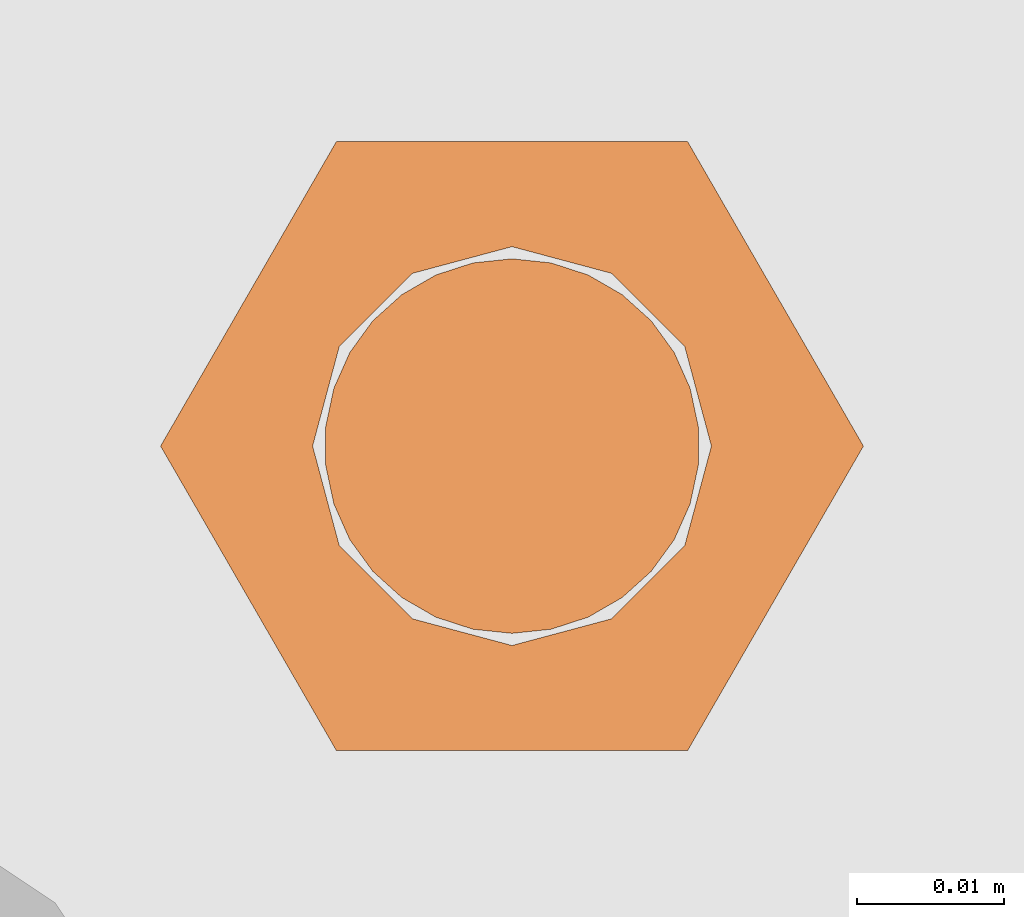
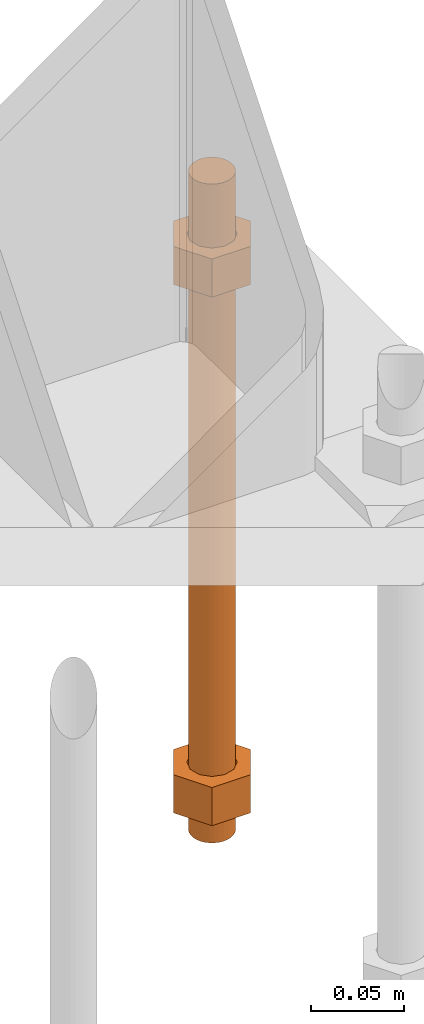
# One storey, part 26 of 89: 1 proxy.
"""IFC4 building model written with IfcOpenShell, lengths in feet."""

import ifcopenshell
import ifcopenshell.guid

model = None  # the IFC model being written
_history = None  # IfcOwnerHistory: only IFC2X3 demands one
_inside = {}  # id of a spatial element -> (the spatial element, [elements in it])
_under = {}  # id of a project, library or spatial element -> (it, [spatial elements below it])
_declared = {}  # id of a project -> (the project, [libraries it declares])
_typed = {}  # id of a type object -> (the type object, [elements of that type])
_made_of = {}  # id of a material, layer set ... -> (it, [elements and type objects made of it])


def new_model(schema):
    """Start an empty IFC model of exactly this schema.

    Asked for "IFC4X3", IfcOpenShell would pick the latest addendum, in which some entities
    have other attributes; the version numbers below select the first issue.
    IFC2X3 requires an IfcOwnerHistory on every rooted entity: one is made here for all.
    """
    global model, _history
    if schema == "IFC4X3":
        model = ifcopenshell.file(schema_version=(4, 3, 0, 0))
    else:
        model = ifcopenshell.file(schema=schema)
    _inside.clear()
    _under.clear()
    _declared.clear()
    _typed.clear()
    _made_of.clear()
    _history = None
    if model.schema == "IFC2X3":
        org = make("IfcOrganization", Name="unknown")
        user = make(
            "IfcPersonAndOrganization",
            ThePerson=make("IfcPerson", FamilyName="unknown"),
            TheOrganization=org,
        )
        app = make(
            "IfcApplication",
            ApplicationDeveloper=org,
            Version="unknown",
            ApplicationFullName="unknown",
            ApplicationIdentifier="unknown",
        )
        _history = make(
            "IfcOwnerHistory",
            OwningUser=user,
            OwningApplication=app,
            ChangeAction="ADDED",
            CreationDate=0,
        )
    return model


def make(cls, **values):
    """One entity of the class cls with the attributes given. An attribute that is None is left unset."""
    return model.create_entity(
        cls, **{name: value for name, value in values.items() if value is not None}
    )


def entity(cls, *values):
    """Any entity or typed value of the class cls, its attributes in the order of the schema. None: left unset."""
    e = model.create_entity(cls)
    for i, value in enumerate(values):
        if value is not None:
            e[i] = value
    return e


def rooted(cls, **values):
    """An entity with a GlobalId (a new one), such as an element, a storey or a relation."""
    return make(cls, GlobalId=ifcopenshell.guid.new(), OwnerHistory=_history, **values)


def si_unit(unit_type, name, prefix=None):
    """IfcSIUnit, for example si_unit("LENGTHUNIT", "METRE", prefix="MILLI")."""
    return make("IfcSIUnit", UnitType=unit_type, Prefix=prefix, Name=name)


def converted_unit(unit_type, name, factor, base, dimensions=None, offset=None):
    """IfcConversionBasedUnit, such as the inch: factor (a typed value) times the base unit."""
    return make(
        "IfcConversionBasedUnit"
        if offset is None
        else "IfcConversionBasedUnitWithOffset",
        ConversionOffset=offset,
        Dimensions=None
        if dimensions is None
        else entity("IfcDimensionalExponents", *dimensions),
        UnitType=unit_type,
        Name=name,
        ConversionFactor=make(
            "IfcMeasureWithUnit", ValueComponent=factor, UnitComponent=base
        ),
    )


def derived_unit(unit_type, elements):
    """IfcDerivedUnit: a product of units, each with its exponent."""
    return make(
        "IfcDerivedUnit",
        Elements=[
            make("IfcDerivedUnitElement", Unit=unit, Exponent=power)
            for unit, power in elements
        ],
        UnitType=unit_type,
    )


def assignment(units):
    """IfcUnitAssignment: the units of a project."""
    return None if units is None else make("IfcUnitAssignment", Units=units)


def point(xyz):
    """IfcCartesianPoint."""
    return None if xyz is None else make("IfcCartesianPoint", Coordinates=xyz)


def direction(xyz):
    """IfcDirection."""
    return None if xyz is None else make("IfcDirection", DirectionRatios=xyz)


def frame(location, z_axis=None, x_axis=None):
    """IfcAxis2Placement3D, a coordinate frame: its origin and axes. An axis left out is left unset."""
    return make(
        "IfcAxis2Placement3D",
        Location=point(location),
        Axis=direction(z_axis),
        RefDirection=direction(x_axis),
    )


def origin():
    """The frame at (0, 0, 0) with its axes left unset."""
    return frame((0.0, 0.0, 0.0))


def place(relative_to, where):
    """IfcLocalPlacement: puts the frame where relative to a parent placement (None: the world)."""
    return make(
        "IfcLocalPlacement", PlacementRelTo=relative_to, RelativePlacement=where
    )


def context(
    kind, dimensions, precision=None, world=None, true_north=None, identifier=None
):
    """IfcGeometricRepresentationContext, for example the 3D "Model" context."""
    return make(
        "IfcGeometricRepresentationContext",
        ContextIdentifier=identifier,
        ContextType=kind,
        CoordinateSpaceDimension=dimensions,
        Precision=precision,
        WorldCoordinateSystem=world,
        TrueNorth=true_north,
    )


def subcontext(parent, identifier, kind, view, scale=None):
    """IfcGeometricRepresentationSubContext, for example "Body" below "Model"."""
    return make(
        "IfcGeometricRepresentationSubContext",
        ContextIdentifier=identifier,
        ContextType=kind,
        ParentContext=parent,
        TargetScale=scale,
        TargetView=view,
    )


def project(units=None, contexts=None):
    """IfcProject with its units and contexts."""
    return rooted(
        "IfcProject",
        Name="project",
        RepresentationContexts=contexts,
        UnitsInContext=assignment(units),
    )


def spatial(cls, under=None, at=None, **own):
    """A site, building, storey or space (cls), placed at a placement, below another one or the project."""
    s = rooted(cls, ObjectPlacement=at, **own)
    if under is not None:
        _under.setdefault(under.id(), (under, []))[1].append(s)
    return s


def faces_of(points, faces, orient=None, outer=None):
    """IfcFace entities. A face is a list of loops; a loop is a list of indices into points, from 0.

    orient and outer hold one flag for each loop. By default every Orientation is true, the
    first loop of a face is its IfcFaceOuterBound and the others are IfcFaceBound.
    """
    made = []
    for i, loops in enumerate(faces):
        bounds = []
        for j, loop in enumerate(loops):
            is_outer = j == 0 if outer is None else outer[i][j]
            bounds.append(
                make(
                    "IfcFaceOuterBound" if is_outer else "IfcFaceBound",
                    Bound=make("IfcPolyLoop", Polygon=[points[k] for k in loop]),
                    Orientation=True if orient is None else orient[i][j],
                )
            )
        made.append(make("IfcFace", Bounds=bounds))
    return made


def faceted_brep(points, faces, orient=None, outer=None, voids=None):
    """IfcFacetedBrep: a solid bounded by flat faces; with voids (closed shells), ...WithVoids."""
    shared = [point(p) for p in points]
    hull = make("IfcClosedShell", CfsFaces=faces_of(shared, faces, orient, outer))
    if voids is None:
        return make("IfcFacetedBrep", Outer=hull)
    return make(
        "IfcFacetedBrepWithVoids",
        Outer=hull,
        Voids=[
            make(cls, CfsFaces=faces_of(shared, fs, o, b)) for cls, fs, o, b in voids
        ],
    )


def shape(context_of_items, identifier, shape_type, items):
    """IfcShapeRepresentation: the items that make up one representation, for example the "Body"."""
    return make(
        "IfcShapeRepresentation",
        ContextOfItems=context_of_items,
        RepresentationIdentifier=identifier,
        RepresentationType=shape_type,
        Items=items,
    )


def source(mapping_origin, context_of_items, identifier, shape_type, items):
    """IfcRepresentationMap: a shape defined once, which mapped items show again and again."""
    return make(
        "IfcRepresentationMap",
        MappingOrigin=mapping_origin,
        MappedRepresentation=shape(context_of_items, identifier, shape_type, items),
    )


def transform(
    local_origin,
    x_axis=None,
    y_axis=None,
    z_axis=None,
    scale=None,
    scale2=None,
    scale3=None,
    uniform=True,
):
    """IfcCartesianTransformationOperator3D, or its non-uniform kind. x_axis, y_axis, z_axis: its Axis1, 2, 3."""
    if uniform:
        return make(
            "IfcCartesianTransformationOperator3D",
            Axis1=direction(x_axis),
            Axis2=direction(y_axis),
            LocalOrigin=point(local_origin),
            Scale=scale,
            Axis3=direction(z_axis),
        )
    return make(
        "IfcCartesianTransformationOperator3DnonUniform",
        Axis1=direction(x_axis),
        Axis2=direction(y_axis),
        LocalOrigin=point(local_origin),
        Scale=scale,
        Axis3=direction(z_axis),
        Scale2=scale2,
        Scale3=scale3,
    )


def mapped(mapping_source, mapping_target):
    """IfcMappedItem: shows the shape of a source again, moved by a transform."""
    return make(
        "IfcMappedItem", MappingSource=mapping_source, MappingTarget=mapping_target
    )


def material(Name=None, Category=None):
    """IfcMaterial."""
    return make("IfcMaterial", Name=Name, Category=Category)


def constituent(of_material, Name=None, Category=None, fraction=None):
    """IfcMaterialConstituent: one of the materials an element consists of."""
    return make(
        "IfcMaterialConstituent",
        Name=Name,
        Material=of_material,
        Fraction=fraction,
        Category=Category,
    )


def constituent_set(constituents=None, Name=None):
    """IfcMaterialConstituentSet."""
    return make(
        "IfcMaterialConstituentSet", Name=Name, MaterialConstituents=constituents
    )


def made_of(thing, what):
    """Note that an element or type object is made of a material, layer set ...; save() writes the relation."""
    if what is not None:
        _made_of.setdefault(what.id(), (what, []))[1].append(thing)
    return thing


def type_object(cls, material=None, **own):
    """A type object (cls), such as IfcWallType, which elements share."""
    return made_of(rooted(cls, **own), material)


def type_shapes(of_type, sources):
    """Give a type object the sources (RepresentationMaps) that its elements show as mapped items."""
    of_type.RepresentationMaps = sources


def element(
    cls,
    number,
    at=None,
    inside=None,
    cuts=None,
    type_object=None,
    material=None,
    context=None,
    identifier="Body",
    shape_type=None,
    held_by="IfcProductDefinitionShape",
    body=None,
    shapes=None,
    **own,
):
    """One element of the class cls, such as IfcWall. Its Tag is "e" and its number.

    at: its placement. inside: the storey or other place that contains it. cuts: it is an
    opening in that element (IfcRelVoidsElement). A single representation is given by context,
    identifier, shape_type and body (its items); several are given by shapes. held_by: the class
    of the entity that holds the representations. save() writes the other relations.
    """
    e = rooted(cls, Tag="e%d" % number, ObjectPlacement=at, **own)
    if body is not None:
        shapes = [shape(context, identifier, shape_type, body)]
    if shapes is not None:
        e.Representation = make(held_by, Representations=shapes)
    if inside is not None:
        _inside.setdefault(inside.id(), (inside, []))[1].append(e)
    if cuts is not None:
        rooted(
            "IfcRelVoidsElement", RelatingBuildingElement=cuts, RelatedOpeningElement=e
        )
    if type_object is not None:
        _typed.setdefault(type_object.id(), (type_object, []))[1].append(e)
    return made_of(e, material)


def aggregate(whole, parts):
    """IfcRelAggregates: a whole, such as a stair, and the parts it consists of."""
    return rooted("IfcRelAggregates", RelatingObject=whole, RelatedObjects=parts)


def save(model, path):
    """Write the relations noted so far, then the file.

    IfcRelAggregates (storeys below a building ...), IfcRelContainedInSpatialStructure (elements
    in a storey), IfcRelDefinesByType, IfcRelAssociatesMaterial and IfcRelDeclares: one each for
    every whole, place, type object, material and project.
    """
    for whole, parts in _under.values():
        aggregate(whole, parts)
    for where, things in _inside.values():
        rooted(
            "IfcRelContainedInSpatialStructure",
            RelatedElements=things,
            RelatingStructure=where,
        )
    for kind, things in _typed.values():
        rooted("IfcRelDefinesByType", RelatedObjects=things, RelatingType=kind)
    for what, things in _made_of.values():
        rooted("IfcRelAssociatesMaterial", RelatedObjects=things, RelatingMaterial=what)
    for by, libraries in _declared.values():
        rooted("IfcRelDeclares", RelatingContext=by, RelatedDefinitions=libraries)
    model.write(path)


model = new_model("IFC4")

# Units and contexts
model_context = context("Model", 3, precision=0.0001, world=origin(), true_north=direction((6.12303176911189e-17, 1.0)))
body_context = subcontext(model_context, "Body", "Model", "MODEL_VIEW")
ifc_project = project(units=[converted_unit("LENGTHUNIT", "FOOT", entity("IfcRatioMeasure", 0.3048), si_unit("LENGTHUNIT", "METRE"), dimensions=[1, 0, 0, 0, 0, 0, 0]), converted_unit("AREAUNIT", "SQUARE FOOT", entity("IfcRatioMeasure", 0.09290304), si_unit("AREAUNIT", "SQUARE_METRE"), dimensions=[2, 0, 0, 0, 0, 0, 0]), converted_unit("VOLUMEUNIT", "CUBIC FOOT", entity("IfcRatioMeasure", 0.028316846592), si_unit("VOLUMEUNIT", "CUBIC_METRE"), dimensions=[3, 0, 0, 0, 0, 0, 0]), si_unit("PLANEANGLEUNIT", "RADIAN"), si_unit("MASSUNIT", "GRAM", prefix="KILO"), derived_unit("MASSDENSITYUNIT", [(si_unit("MASSUNIT", "GRAM", prefix="KILO"), 1), (si_unit("LENGTHUNIT", "METRE"), -3)]), derived_unit("MOMENTOFINERTIAUNIT", [(si_unit("LENGTHUNIT", "METRE"), 4)]), si_unit("TIMEUNIT", "SECOND"), si_unit("FREQUENCYUNIT", "HERTZ"), si_unit("THERMODYNAMICTEMPERATUREUNIT", "DEGREE_CELSIUS"), derived_unit("THERMALTRANSMITTANCEUNIT", [(si_unit("MASSUNIT", "GRAM", prefix="KILO"), 1), (si_unit("THERMODYNAMICTEMPERATUREUNIT", "KELVIN"), -1), (si_unit("TIMEUNIT", "SECOND"), -3)]), derived_unit("VOLUMETRICFLOWRATEUNIT", [(si_unit("LENGTHUNIT", "METRE"), 3), (si_unit("TIMEUNIT", "SECOND"), -1)]), si_unit("ELECTRICCURRENTUNIT", "AMPERE"), si_unit("ELECTRICVOLTAGEUNIT", "VOLT"), si_unit("POWERUNIT", "WATT"), si_unit("FORCEUNIT", "NEWTON"), si_unit("ILLUMINANCEUNIT", "LUX"), si_unit("LUMINOUSFLUXUNIT", "LUMEN"), si_unit("LUMINOUSINTENSITYUNIT", "CANDELA"), derived_unit("USERDEFINED", [(si_unit("MASSUNIT", "GRAM", prefix="KILO"), -1), (si_unit("LENGTHUNIT", "METRE"), -2), (si_unit("TIMEUNIT", "SECOND"), 3), (si_unit("LUMINOUSFLUXUNIT", "LUMEN"), 1)]), derived_unit("LINEARVELOCITYUNIT", [(si_unit("LENGTHUNIT", "METRE"), 1), (si_unit("TIMEUNIT", "SECOND"), -1)]), si_unit("PRESSUREUNIT", "PASCAL"), derived_unit("USERDEFINED", [(si_unit("LENGTHUNIT", "METRE"), -2), (si_unit("MASSUNIT", "GRAM", prefix="KILO"), 1), (si_unit("TIMEUNIT", "SECOND"), -2)]), derived_unit("LINEARFORCEUNIT", [(si_unit("MASSUNIT", "GRAM", prefix="KILO"), 1), (si_unit("LENGTHUNIT", "METRE"), 1), (si_unit("TIMEUNIT", "SECOND"), -2), (si_unit("LENGTHUNIT", "METRE"), -1)]), derived_unit("PLANARFORCEUNIT", [(si_unit("MASSUNIT", "GRAM", prefix="KILO"), 1), (si_unit("LENGTHUNIT", "METRE"), 1), (si_unit("TIMEUNIT", "SECOND"), -2), (si_unit("LENGTHUNIT", "METRE"), -2)])], contexts=[model_context])

# Site, building, storey
site_placement = place(None, origin())
site = spatial("IfcSite", under=ifc_project, at=site_placement, CompositionType="ELEMENT")
building_placement = place(site_placement, frame((-472.238160486, -49.138065117, 0.0)))
building = spatial("IfcBuilding", under=site, at=building_placement, CompositionType="ELEMENT")
storey_placement = place(building_placement, origin())
storey = spatial("IfcBuildingStorey", under=building, at=storey_placement, Name="Level 1", CompositionType="ELEMENT", Elevation=0.0)

# Proxy
ifc_material_1 = material(Name="Color 7721", Category="Materials")
ifc_constituent_1 = constituent(ifc_material_1, Name="Color 7721", Category="Materials")
ifc_material_2 = material(Name="Color 7720", Category="Materials")
ifc_constituent_2 = constituent(ifc_material_2, Name="Color 7720", Category="Materials")
ifc_constituent_set = constituent_set(constituents=[ifc_constituent_1, ifc_constituent_2])
building_element_proxy_type = type_object("IfcBuildingElementProxyType", Name="rb2", PredefinedType="NOTDEFINED", material=ifc_material_1)
shared_shape = source(origin(), body_context, "Body", "Brep", [
    faceted_brep([(0.122545547339286, 0.0677083333333712, 0.0626666666666664), (0.156365697905557, 0.0677083333333712, 0.0626666666666664), (0.11727427342916, 0.135416666666742, 0.0626666666666664), (0.0390914244764247, 0.135416666666742, 0.0626666666666664), (0.0, 0.0677083333333712, 0.0626666666666664), (0.0338201505662994, 0.0677083333333712, 0.0626666666666664), (0.0397636251696838, 0.089889682526632, 0.0626666666666664), (0.0560014997595601, 0.106127557116452, 0.0626666666666664), (0.0781828489527925, 0.112071031719893, 0.0626666666666664), (0.100364198146025, 0.106127557116452, 0.0626666666666664), (0.116602072735901, 0.089889682526632, 0.0626666666666664), (0.11727427342916, 0.0, 0.0626666666666664), (0.0390914244764247, 0.0, 0.0626666666666664), (0.0397636251696838, 0.0455269841401105, 0.0626666666666664), (0.0560014997595601, 0.029289109550291, 0.0626666666666664), (0.0781828489527925, 0.0233456349468497, 0.0626666666666664), (0.100364198146025, 0.029289109550291, 0.0626666666666664), (0.116602072735901, 0.0455269841401105, 0.0626666666666664), (0.0, 0.0677083333333712, 0.144697916666667), (0.0390914244763962, 0.135416666666742, 0.144697916666667), (0.11727427342916, 0.135416666666742, 0.144697916666667), (0.156365697905528, 0.0677083333333712, 0.144697916666667), (0.117274273429189, 0.0, 0.144697916666667), (0.0390914244764247, 0.0, 0.144697916666667), (0.122545547339286, 0.0677083333333712, 0.144697916666666), (0.0338201505662994, 0.0677083333333712, 0.144697916666666), (0.0397636251696838, 0.0455269841401105, 0.144697916666666), (0.0560014997595601, 0.029289109550291, 0.144697916666666), (0.0781828489527925, 0.0233456349468497, 0.144697916666666), (0.100364198146025, 0.029289109550291, 0.144697916666666), (0.116602072735901, 0.0455269841401105, 0.144697916666666), (0.0397636251696838, 0.089889682526632, 0.144697916666666), (0.0560014997595601, 0.106127557116452, 0.144697916666666), (0.0781828489527925, 0.112071031719893, 0.144697916666666), (0.100364198146025, 0.106127557116452, 0.144697916666666), (0.116602072735901, 0.089889682526632, 0.144697916666666)], [[[0, 1, 2, 3, 4, 5, 6, 7, 8, 9, 10]], [[1, 11, 12, 4, 5, 13, 14, 15, 16, 17, 0]], [[4, 18, 19, 3]], [[3, 19, 20, 2]], [[2, 20, 21, 1]], [[1, 21, 22, 11]], [[11, 22, 23, 12]], [[12, 23, 18, 4]], [[24, 21, 22, 23, 18, 25, 26, 27, 28, 29, 30]], [[21, 20, 19, 18, 25, 31, 32, 33, 34, 35, 24]], [[25, 5, 6, 31]], [[31, 6, 7, 32]], [[32, 7, 8, 33]], [[33, 8, 9, 34]], [[34, 9, 10, 35]], [[35, 10, 0, 24]], [[24, 0, 17, 30]], [[30, 17, 16, 29]], [[29, 16, 15, 28]], [[28, 15, 14, 27]], [[27, 14, 13, 26]], [[26, 13, 5, 25]]]),
    faceted_brep([(0.0338201505662994, 0.0677083333333712, 1.28108333333333), (0.0, 0.0677083333333712, 1.28108333333333), (0.0390914244764247, 0.135416666666742, 1.28108333333333), (0.11727427342916, 0.135416666666742, 1.28108333333333), (0.156365697905557, 0.0677083333333712, 1.28108333333333), (0.122545547339286, 0.0677083333333712, 1.28108333333333), (0.116602072735901, 0.089889682526632, 1.28108333333333), (0.100364198146025, 0.106127557116452, 1.28108333333333), (0.0781828489527925, 0.112071031719893, 1.28108333333333), (0.0560014997595601, 0.106127557116452, 1.28108333333333), (0.0397636251696838, 0.089889682526632, 1.28108333333333), (0.0390914244764247, 0.0, 1.28108333333333), (0.11727427342916, 0.0, 1.28108333333333), (0.116602072735901, 0.0455269841401105, 1.28108333333333), (0.100364198146025, 0.029289109550291, 1.28108333333333), (0.0781828489527925, 0.0233456349468497, 1.28108333333333), (0.0560014997595601, 0.029289109550291, 1.28108333333333), (0.0397636251696838, 0.0455269841401105, 1.28108333333333), (0.156365697905585, 0.0677083333333712, 1.19905208333333), (0.117274273429189, 0.135416666666742, 1.19905208333333), (0.0390914244764247, 0.135416666666742, 1.19905208333333), (0.0, 0.0677083333333712, 1.19905208333333), (0.0390914244763962, 0.0, 1.19905208333333), (0.11727427342916, 0.0, 1.19905208333333), (0.0338201505662994, 0.0677083333333712, 1.19905208333333), (0.122545547339286, 0.0677083333333712, 1.19905208333333), (0.116602072735901, 0.0455269841401105, 1.19905208333333), (0.100364198146025, 0.029289109550291, 1.19905208333333), (0.0781828489527925, 0.0233456349468497, 1.19905208333333), (0.0560014997595601, 0.029289109550291, 1.19905208333333), (0.0397636251696838, 0.0455269841401105, 1.19905208333333), (0.116602072735901, 0.089889682526632, 1.19905208333333), (0.100364198146025, 0.106127557116452, 1.19905208333333), (0.0781828489527925, 0.112071031719893, 1.19905208333333), (0.0560014997595601, 0.106127557116452, 1.19905208333333), (0.0397636251696838, 0.089889682526632, 1.19905208333333)], [[[0, 1, 2, 3, 4, 5, 6, 7, 8, 9, 10]], [[1, 11, 12, 4, 5, 13, 14, 15, 16, 17, 0]], [[4, 18, 19, 3]], [[3, 19, 20, 2]], [[2, 20, 21, 1]], [[1, 21, 22, 11]], [[11, 22, 23, 12]], [[12, 23, 18, 4]], [[24, 21, 22, 23, 18, 25, 26, 27, 28, 29, 30]], [[21, 20, 19, 18, 25, 31, 32, 33, 34, 35, 24]], [[25, 5, 6, 31]], [[31, 6, 7, 32]], [[32, 7, 8, 33]], [[33, 8, 9, 34]], [[34, 9, 10, 35]], [[35, 10, 0, 24]], [[24, 0, 17, 30]], [[30, 17, 16, 29]], [[29, 16, 15, 28]], [[28, 15, 14, 27]], [[27, 14, 13, 26]], [[26, 13, 5, 25]]]),
    faceted_brep([(0.0781828489527925, 0.0260416666667425, 0.0), (0.0695198618353743, 0.0269521833027966, 0.0), (0.0612354888246216, 0.029643939264929, 0.0), (0.0536917967739328, 0.0339992919010683, 0.0), (0.0472184812245757, 0.0398278914017283, 0.0), (0.0420984571284464, 0.046875, 0.0), (0.0385554941071575, 0.0548326252344395, 0.0), (0.0367444366457903, 0.0633529806972319, 0.0), (0.0367444366457903, 0.0720636859695105, 0.0), (0.0385554941071575, 0.0805840414323029, 0.0), (0.0420984571284464, 0.0885416666667425, 0.0), (0.0472184812245757, 0.0955887752650142, 0.0), (0.0536917967739328, 0.101417374765674, 0.0), (0.0612354888246216, 0.105772727401813, 0.0), (0.0695198618353743, 0.108464483363946, 0.0), (0.0781828489527925, 0.109375, 0.0), (0.0868458360702107, 0.108464483363946, 0.0), (0.0951302090809634, 0.105772727401813, 0.0), (0.102673901131652, 0.101417374765674, 0.0), (0.109147216681009, 0.0955887752650142, 0.0), (0.114267240777139, 0.0885416666667425, 0.0), (0.117810203798427, 0.0805840414323029, 0.0), (0.119621261259795, 0.0720636859695105, 0.0), (0.119621261259795, 0.0633529806972319, 0.0), (0.117810203798427, 0.0548326252344395, 0.0), (0.114267240777139, 0.046875, 0.0), (0.109147216681009, 0.0398278914017283, 0.0), (0.102673901131652, 0.0339992919010683, 0.0), (0.0951302090809634, 0.029643939264929, 0.0), (0.0868458360702107, 0.0269521833027966, 0.0), (0.0868458360702107, 0.0269521833027966, 1.41666666666667), (0.0951302090809634, 0.029643939264929, 1.41666666666667), (0.102673901131652, 0.0339992919010683, 1.41666666666667), (0.109147216681009, 0.0398278914017283, 1.41666666666667), (0.114267240777139, 0.046875, 1.41666666666667), (0.117810203798427, 0.0548326252344395, 1.41666666666667), (0.119621261259795, 0.0633529806972319, 1.41666666666667), (0.119621261259795, 0.0720636859695105, 1.41666666666667), (0.117810203798427, 0.0805840414323029, 1.41666666666667), (0.114267240777139, 0.0885416666667425, 1.41666666666667), (0.109147216681009, 0.0955887752650142, 1.41666666666667), (0.102673901131652, 0.101417374765674, 1.41666666666667), (0.0951302090809634, 0.105772727401813, 1.41666666666667), (0.0868458360702107, 0.108464483363946, 1.41666666666667), (0.0781828489527925, 0.109375, 1.41666666666667), (0.0695198618353743, 0.108464483363946, 1.41666666666667), (0.0612354888246216, 0.105772727401813, 1.41666666666667), (0.0536917967739328, 0.101417374765674, 1.41666666666667), (0.0472184812245757, 0.0955887752650142, 1.41666666666667), (0.0420984571284464, 0.0885416666667425, 1.41666666666667), (0.0385554941071575, 0.0805840414323029, 1.41666666666667), (0.0367444366457903, 0.0720636859695105, 1.41666666666667), (0.0367444366457903, 0.0633529806972319, 1.41666666666667), (0.0385554941071575, 0.0548326252344395, 1.41666666666667), (0.0420984571284464, 0.046875, 1.41666666666667), (0.0472184812245757, 0.0398278914017283, 1.41666666666667), (0.0536917967739328, 0.0339992919010683, 1.41666666666667), (0.0612354888246216, 0.029643939264929, 1.41666666666667), (0.0695198618353743, 0.0269521833027966, 1.41666666666667), (0.0781828489527925, 0.0260416666667425, 1.41666666666667), (0.0695198618353743, 0.0269521833027966, 0.25), (0.0781828489527925, 0.0260416666667425, 0.25), (0.0612354888246216, 0.029643939264929, 0.25), (0.0536917967739328, 0.0339992919010683, 0.25), (0.0472184812246326, 0.0398278914017283, 0.25), (0.0420984571284464, 0.046875, 0.25), (0.0385554941071575, 0.0548326252344395, 0.25), (0.0367444366457903, 0.0633529806972319, 0.25), (0.0367444366457903, 0.0720636859695105, 0.25), (0.038555494107186, 0.0805840414323029, 0.25), (0.0420984571284464, 0.0885416666667425, 0.25), (0.0472184812245757, 0.0955887752650142, 0.25), (0.0536917967738759, 0.101417374765674, 0.25), (0.0612354888246216, 0.105772727401813, 0.25), (0.0695198618353743, 0.108464483363946, 0.25), (0.0781828489527925, 0.109375, 0.25), (0.0868458360702107, 0.108464483363946, 0.25), (0.0951302090809634, 0.105772727401813, 0.25), (0.102673901131652, 0.101417374765674, 0.25), (0.109147216680952, 0.0955887752650142, 0.25), (0.114267240777139, 0.0885416666667425, 0.25), (0.117810203798427, 0.0805840414323029, 0.25), (0.119621261259795, 0.0720636859695105, 0.25), (0.119621261259795, 0.0633529806972319, 0.25), (0.117810203798399, 0.0548326252344395, 0.25), (0.114267240777139, 0.046875, 0.25), (0.109147216681009, 0.0398278914017283, 0.25), (0.102673901131709, 0.0339992919010683, 0.25), (0.0951302090809634, 0.029643939264929, 0.25), (0.0868458360702107, 0.0269521833027966, 0.25), (0.0695198618353743, 0.0269521833027966, 0.916666666666667), (0.0781828489527925, 0.0260416666667425, 0.916666666666667), (0.0612354888246216, 0.029643939264929, 0.916666666666667), (0.0536917967739328, 0.0339992919010683, 0.916666666666667), (0.0472184812246326, 0.0398278914017283, 0.916666666666667), (0.0420984571284464, 0.046875, 0.916666666666667), (0.0385554941071575, 0.0548326252344395, 0.916666666666667), (0.0367444366457903, 0.0633529806972319, 0.916666666666667), (0.0367444366457903, 0.0720636859695105, 0.916666666666667), (0.038555494107186, 0.0805840414323029, 0.916666666666667), (0.0420984571284464, 0.0885416666667425, 0.916666666666667), (0.0472184812245757, 0.0955887752650142, 0.916666666666667), (0.0536917967738759, 0.101417374765674, 0.916666666666667), (0.0612354888246216, 0.105772727401813, 0.916666666666667), (0.0695198618353743, 0.108464483363946, 0.916666666666667), (0.0781828489527925, 0.109375, 0.916666666666667), (0.0868458360702107, 0.108464483363946, 0.916666666666667), (0.0951302090809634, 0.105772727401813, 0.916666666666667), (0.102673901131652, 0.101417374765674, 0.916666666666667), (0.109147216680952, 0.0955887752650142, 0.916666666666667), (0.114267240777139, 0.0885416666667425, 0.916666666666667), (0.117810203798427, 0.0805840414323029, 0.916666666666667), (0.119621261259795, 0.0720636859695105, 0.916666666666667), (0.119621261259795, 0.0633529806972319, 0.916666666666667), (0.117810203798399, 0.0548326252344395, 0.916666666666667), (0.114267240777139, 0.046875, 0.916666666666667), (0.109147216681009, 0.0398278914017283, 0.916666666666667), (0.102673901131709, 0.0339992919010683, 0.916666666666667), (0.0951302090809634, 0.029643939264929, 0.916666666666667), (0.0868458360702107, 0.0269521833027966, 0.916666666666667)], [[[0, 1, 2, 3, 4, 5, 6, 7, 8, 9, 10, 11, 12, 13, 14, 15, 16, 17, 18, 19, 20, 21, 22, 23, 24, 25, 26, 27, 28, 29]], [[30, 31, 32, 33, 34, 35, 36, 37, 38, 39, 40, 41, 42, 43, 44, 45, 46, 47, 48, 49, 50, 51, 52, 53, 54, 55, 56, 57, 58, 59]], [[60, 1, 0, 61]], [[62, 2, 1, 60]], [[63, 3, 2, 62]], [[64, 4, 3, 63]], [[65, 5, 4, 64]], [[66, 6, 5, 65]], [[67, 7, 6, 66]], [[68, 8, 7, 67]], [[69, 9, 8, 68]], [[70, 10, 9, 69]], [[71, 11, 10, 70]], [[72, 12, 11, 71]], [[73, 13, 12, 72]], [[74, 14, 13, 73]], [[75, 15, 14, 74]], [[76, 16, 15, 75]], [[77, 17, 16, 76]], [[78, 18, 17, 77]], [[79, 19, 18, 78]], [[80, 20, 19, 79]], [[81, 21, 20, 80]], [[82, 22, 21, 81]], [[83, 23, 22, 82]], [[84, 24, 23, 83]], [[85, 25, 24, 84]], [[86, 26, 25, 85]], [[87, 27, 26, 86]], [[88, 28, 27, 87]], [[89, 29, 28, 88]], [[61, 0, 29, 89]], [[90, 60, 61, 91]], [[92, 62, 60, 90]], [[93, 63, 62, 92]], [[94, 64, 63, 93]], [[95, 65, 64, 94]], [[96, 66, 65, 95]], [[97, 67, 66, 96]], [[98, 68, 67, 97]], [[99, 69, 68, 98]], [[100, 70, 69, 99]], [[101, 71, 70, 100]], [[102, 72, 71, 101]], [[103, 73, 72, 102]], [[104, 74, 73, 103]], [[105, 75, 74, 104]], [[106, 76, 75, 105]], [[107, 77, 76, 106]], [[108, 78, 77, 107]], [[109, 79, 78, 108]], [[110, 80, 79, 109]], [[111, 81, 80, 110]], [[112, 82, 81, 111]], [[113, 83, 82, 112]], [[114, 84, 83, 113]], [[115, 85, 84, 114]], [[116, 86, 85, 115]], [[117, 87, 86, 116]], [[118, 88, 87, 117]], [[119, 89, 88, 118]], [[91, 61, 89, 119]], [[58, 90, 91, 59]], [[57, 92, 90, 58]], [[56, 93, 92, 57]], [[55, 94, 93, 56]], [[54, 95, 94, 55]], [[53, 96, 95, 54]], [[52, 97, 96, 53]], [[51, 98, 97, 52]], [[50, 99, 98, 51]], [[49, 100, 99, 50]], [[48, 101, 100, 49]], [[47, 102, 101, 48]], [[46, 103, 102, 47]], [[45, 104, 103, 46]], [[44, 105, 104, 45]], [[43, 106, 105, 44]], [[42, 107, 106, 43]], [[41, 108, 107, 42]], [[40, 109, 108, 41]], [[39, 110, 109, 40]], [[38, 111, 110, 39]], [[37, 112, 111, 38]], [[36, 113, 112, 37]], [[35, 114, 113, 36]], [[34, 115, 114, 35]], [[33, 116, 115, 34]], [[32, 117, 116, 33]], [[31, 118, 117, 32]], [[30, 119, 118, 31]], [[59, 91, 119, 30]]]),
])
type_shapes(building_element_proxy_type, [shared_shape])
proxy_placement = place(building_placement, frame((200.25515048438, 1000.265625, -1.45833333333333)))
element("IfcBuildingElementProxy", 1, at=proxy_placement, inside=storey, type_object=building_element_proxy_type, material=ifc_constituent_set, Name="rb2 312:rb2 312", ObjectType="rb2 312:rb2 312", PredefinedType="NOTDEFINED", context=body_context, shape_type="MappedRepresentation", body=[
    mapped(shared_shape, transform((0.0, 0.0, 0.0), scale=1.0)),
])

save(model, "model.ifc")
